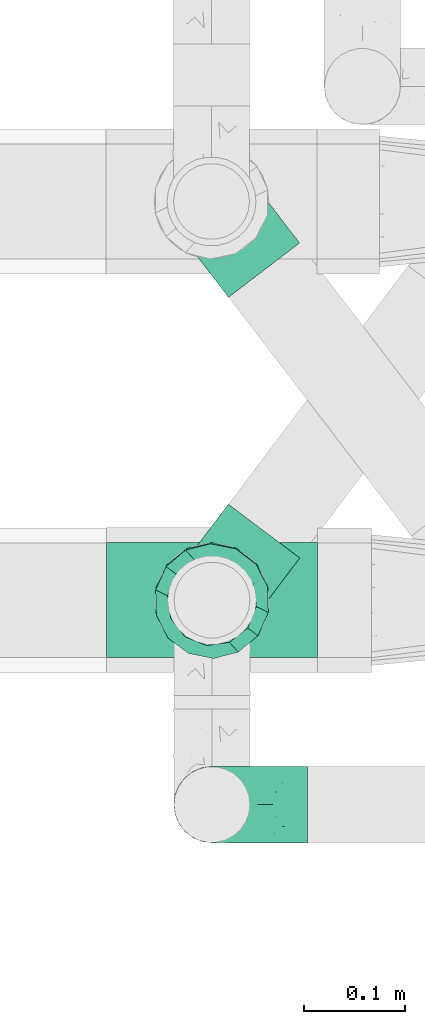
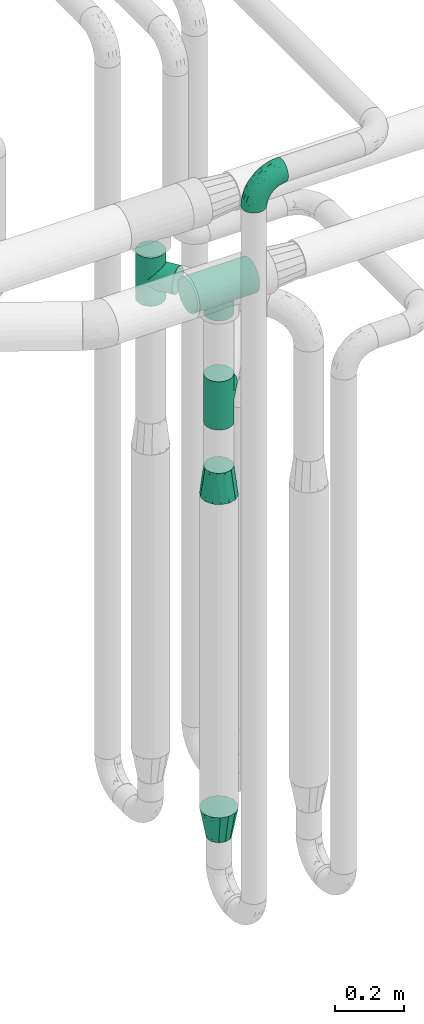
# One storey, part 629 of 827: 6 flow fittings.
"""IFC2X3 building model written with IfcOpenShell, lengths in millimetres."""

from ifc_helpers import new_model, entity, si_unit, converted_unit, derived_unit, direction, frame, origin, place, context, subcontext, project, spatial, faceted_brep, source, transform, mapped, material, type_object, type_shapes, element, save


model = new_model("IFC2X3")

# Units and contexts
model_context = context("Model", 3, precision=0.01, world=origin(), true_north=direction((6.12303176911189e-17, 1.0)))
body_context = subcontext(model_context, "Body", "Model", "MODEL_VIEW")
ifc_project = project(units=[si_unit("LENGTHUNIT", "METRE", prefix="MILLI"), si_unit("AREAUNIT", "SQUARE_METRE"), si_unit("VOLUMEUNIT", "CUBIC_METRE"), converted_unit("PLANEANGLEUNIT", "DEGREE", entity("IfcRatioMeasure", 0.0174532925199433), si_unit("PLANEANGLEUNIT", "RADIAN"), dimensions=[0, 0, 0, 0, 0, 0, 0]), si_unit("MASSUNIT", "GRAM", prefix="KILO"), derived_unit("MASSDENSITYUNIT", [(si_unit("MASSUNIT", "GRAM", prefix="KILO"), 1), (si_unit("LENGTHUNIT", "METRE"), -3)]), derived_unit("MOMENTOFINERTIAUNIT", [(si_unit("LENGTHUNIT", "METRE"), 4)]), si_unit("TIMEUNIT", "SECOND"), si_unit("FREQUENCYUNIT", "HERTZ"), si_unit("THERMODYNAMICTEMPERATUREUNIT", "DEGREE_CELSIUS"), derived_unit("THERMALTRANSMITTANCEUNIT", [(si_unit("MASSUNIT", "GRAM", prefix="KILO"), 1), (si_unit("THERMODYNAMICTEMPERATUREUNIT", "KELVIN"), -1), (si_unit("TIMEUNIT", "SECOND"), -3)]), derived_unit("VOLUMETRICFLOWRATEUNIT", [(si_unit("LENGTHUNIT", "METRE"), 3), (si_unit("TIMEUNIT", "SECOND"), -1)]), derived_unit("MASSFLOWRATEUNIT", [(si_unit("MASSUNIT", "GRAM", prefix="KILO"), 1), (si_unit("TIMEUNIT", "SECOND"), -1)]), derived_unit("ROTATIONALFREQUENCYUNIT", [(si_unit("TIMEUNIT", "SECOND"), -1)]), si_unit("ELECTRICCURRENTUNIT", "AMPERE"), si_unit("ELECTRICVOLTAGEUNIT", "VOLT"), si_unit("POWERUNIT", "WATT"), si_unit("FORCEUNIT", "NEWTON", prefix="KILO"), si_unit("ILLUMINANCEUNIT", "LUX"), si_unit("LUMINOUSFLUXUNIT", "LUMEN"), si_unit("LUMINOUSINTENSITYUNIT", "CANDELA"), derived_unit("USERDEFINED", [(si_unit("MASSUNIT", "GRAM", prefix="KILO"), -1), (si_unit("LENGTHUNIT", "METRE"), -2), (si_unit("TIMEUNIT", "SECOND"), 3), (si_unit("LUMINOUSFLUXUNIT", "LUMEN"), 1)]), derived_unit("LINEARVELOCITYUNIT", [(si_unit("LENGTHUNIT", "METRE"), 1), (si_unit("TIMEUNIT", "SECOND"), -1)]), si_unit("PRESSUREUNIT", "PASCAL"), derived_unit("USERDEFINED", [(si_unit("LENGTHUNIT", "METRE"), -2), (si_unit("MASSUNIT", "GRAM", prefix="KILO"), 1), (si_unit("TIMEUNIT", "SECOND"), -2)]), derived_unit("LINEARFORCEUNIT", [(si_unit("MASSUNIT", "GRAM", prefix="KILO"), 1), (si_unit("LENGTHUNIT", "METRE"), 1), (si_unit("TIMEUNIT", "SECOND"), -2), (si_unit("LENGTHUNIT", "METRE"), -1)]), derived_unit("PLANARFORCEUNIT", [(si_unit("MASSUNIT", "GRAM", prefix="KILO"), 1), (si_unit("LENGTHUNIT", "METRE"), 1), (si_unit("TIMEUNIT", "SECOND"), -2), (si_unit("LENGTHUNIT", "METRE"), -2)])], contexts=[model_context])

# Site, building, storey
site_placement = place(None, origin())
site = spatial("IfcSite", under=ifc_project, at=site_placement, CompositionType="ELEMENT")
building_placement = place(site_placement, origin())
building = spatial("IfcBuilding", under=site, at=building_placement, CompositionType="ELEMENT")
storey_placement = place(building_placement, frame((0.0, 0.0, 28200.0)))
storey = spatial("IfcBuildingStorey", under=building, at=storey_placement, Name="08", CompositionType="ELEMENT", Elevation=28200.0)

# Flow fittings
ifc_material = material()
pipe_fitting_type_1 = type_object("IfcPipeFittingType", Name="ADSK_1", PredefinedType="NOTDEFINED", material=ifc_material)
shared_shape_1 = source(origin(), body_context, "Body", "Brep", [
    faceted_brep([(-95.0, 19.02, -32.95), (-95.0, 9.85, -36.75), (-95.0, 0.0, -38.05), (-95.0, -9.85, -36.75), (-95.0, -19.03, -32.95), (-95.0, -26.91, -26.91), (-95.0, -32.95, -19.03), (-95.0, -36.75, -9.85), (-95.0, -38.05, 0.0), (-95.0, -36.75, 9.85), (-95.0, -32.95, 19.02), (-95.0, -26.91, 26.91), (-95.0, -19.03, 32.95), (-95.0, -9.85, 36.75), (-95.0, 0.0, 38.05), (-95.0, 9.85, 36.75), (-95.0, 19.02, 32.95), (-95.0, 26.91, 26.91), (-95.0, 32.95, 19.02), (-95.0, 36.75, 9.85), (-95.0, 38.05, 0.0), (-95.0, 36.75, -9.85), (-95.0, 32.95, -19.03), (-95.0, 26.91, -26.91), (0.0, 95.0, -38.05), (-9.85, 95.0, -36.75), (-19.02, 95.0, -32.95), (-26.91, 95.0, -26.91), (-32.95, 95.0, -19.03), (-36.75, 95.0, -9.85), (-38.05, 95.0, 0.0), (-36.75, 95.0, 9.85), (-32.95, 95.0, 19.02), (-26.91, 95.0, 26.91), (-19.02, 95.0, 32.95), (-9.85, 95.0, 36.75), (0.0, 95.0, 38.05), (9.85, 95.0, 36.75), (19.03, 95.0, 32.95), (26.91, 95.0, 26.91), (32.95, 95.0, 19.02), (36.75, 95.0, 9.85), (38.05, 95.0, 0.0), (36.75, 95.0, -9.85), (32.95, 95.0, -19.03), (26.91, 95.0, -26.91), (19.03, 95.0, -32.95), (9.85, 95.0, -36.75), (-7.99, -4.96, 6.3), (-0.92, 0.92, 0.0), (4.62, 8.1, 8.01), (-76.19, -35.57, 0.0), (-64.32, -32.32, 12.43), (20.51, 62.45, 28.68), (-60.56, -33.52, 0.0), (-70.4, -13.47, 34.42), (-39.61, -5.88, 32.32), (-49.6, 2.07, 37.1), (-70.34, -28.81, 21.71), (14.64, 40.81, 26.5), (5.88, 39.61, 32.32), (3.59, 20.77, 25.31), (-40.45, 68.06, 16.75), (-62.45, -20.51, 28.68), (-44.52, -26.87, 0.0), (-28.47, -20.22, 0.0), (-26.43, -17.83, 8.75), (-76.1, 39.63, 10.76), (-72.74, 37.58, 18.19), (-60.35, 46.18, 14.61), (-13.4, 13.4, 32.12), (-20.77, -3.59, 25.31), (-14.66, 81.47, 35.56), (-6.22, 71.26, 37.92), (-57.5, 42.48, 22.79), (-15.0, 34.74, 37.7), (-27.1, 12.08, 36.05), (-9.2, 28.81, 35.63), (-79.98, 23.7, 30.95), (-73.68, -4.3, 37.48), (-30.74, 21.67, 37.97), (-62.36, 47.59, 6.79), (-72.71, 32.83, 24.69), (-67.42, 7.02, 37.95), (-32.13, 75.27, 24.51), (-43.46, 51.47, 26.26), (-24.98, 73.15, 31.29), (20.59, 41.28, 19.85), (7.79, 16.09, 15.86), (-73.21, 42.39, 0.0), (-54.73, 54.73, 0.0), (-73.44, 15.79, 35.79), (-5.94, 4.32, 20.43), (28.81, 70.34, 21.71), (32.32, 64.32, 12.43), (-53.59, 26.2, 35.09), (-52.02, 19.31, 37.21), (21.38, 33.53, 10.34), (26.87, 44.52, 0.0), (-48.28, 12.14, 38.05), (4.3, 73.68, 37.48), (-44.08, -25.52, 12.79), (-41.28, -20.59, 19.85), (35.57, 76.19, 0.0), (-47.26, 54.3, 20.18), (-47.4, 61.99, 8.58), (-42.39, 73.21, 0.0), (-39.67, 78.86, 7.21), (-45.69, 36.84, 33.11), (-32.83, 50.13, 33.35), (13.47, 70.4, 34.42), (-18.25, 63.73, 36.07), (-40.63, -13.75, 27.22), (-16.63, 46.37, 37.95), (-53.47, 38.79, 28.59), (-26.07, 48.54, 36.15), (-34.51, 34.51, 36.86), (-2.07, 49.6, 37.1), (-22.79, -10.49, 19.23), (-61.73, 28.67, 31.87), (9.65, 14.7, 0.0), (20.22, 28.47, 0.0), (33.52, 60.56, 0.0), (-11.42, -5.44, 13.25), (-14.7, -9.65, 0.0), (-81.47, 14.66, -35.56), (-62.45, -20.51, -28.68), (-71.26, 6.22, -37.92), (-75.27, 32.13, -24.51), (-73.15, 24.98, -31.29), (13.47, 70.4, -34.42), (5.88, 39.61, -32.32), (-2.07, 49.6, -37.1), (-78.86, 39.67, -7.21), (-70.4, -13.47, -34.42), (-39.61, -5.88, -32.32), (-61.99, 47.4, -8.58), (32.32, 64.32, -12.43), (28.81, 70.34, -21.71), (-63.73, 18.25, -36.07), (-50.13, 32.83, -33.35), (4.3, 73.68, -37.48), (-7.02, 67.42, -37.95), (-39.63, 76.1, -10.76), (-46.18, 60.35, -14.61), (-47.59, 62.36, -6.79), (-64.32, -32.32, -12.43), (-26.2, 53.59, -35.09), (-15.79, 73.44, -35.79), (-19.31, 52.02, -37.21), (-37.58, 72.74, -18.19), (-70.34, -28.81, -21.71), (-42.48, 57.5, -22.79), (-38.79, 53.47, -28.59), (-51.47, 43.46, -26.26), (-32.83, 72.71, -24.69), (-46.37, 16.63, -37.95), (-73.68, -4.3, -37.48), (-41.28, -20.59, -19.85), (-44.08, -25.52, -12.79), (13.75, 40.63, -27.22), (20.51, 62.45, -28.68), (-68.06, 40.45, -16.75), (-54.3, 47.26, -20.18), (-12.14, 48.28, -38.05), (-21.67, 30.74, -37.97), (-36.84, 45.69, -33.11), (-11.42, -5.44, -13.25), (7.79, 16.09, -15.86), (4.62, 8.1, -8.01), (-23.7, 79.98, -30.95), (-26.43, -17.83, -8.75), (-7.99, -4.96, -6.3), (-40.81, -14.64, -26.5), (-20.77, -3.59, -25.31), (-34.74, 15.0, -37.7), (-12.08, 27.1, -36.05), (-28.81, 9.2, -35.63), (-22.79, -10.49, -19.23), (21.38, 33.53, -10.34), (20.59, 41.28, -19.85), (-48.54, 26.07, -36.15), (-49.6, 2.07, -37.1), (-13.4, 13.4, -32.12), (3.59, 20.77, -25.31), (-28.67, 61.73, -31.87), (-34.51, 34.51, -36.86), (-5.94, 4.32, -20.43)], [[[0, 1, 2, 3, 4, 5, 6, 7, 8, 9, 10, 11, 12, 13, 14, 15, 16, 17, 18, 19, 20, 21, 22, 23]], [[24, 25, 26, 27, 28, 29, 30, 31, 32, 33, 34, 35, 36, 37, 38, 39, 40, 41, 42, 43, 44, 45, 46, 47]], [[48, 49, 50]], [[51, 52, 9]], [[53, 39, 38]], [[9, 52, 10]], [[54, 52, 51]], [[55, 56, 57]], [[11, 10, 58]], [[59, 60, 61]], [[32, 31, 62]], [[63, 12, 11]], [[63, 55, 12]], [[64, 65, 66]], [[67, 68, 69]], [[70, 56, 71]], [[35, 72, 73]], [[69, 68, 74]], [[75, 76, 77]], [[16, 78, 17]], [[13, 79, 14]], [[76, 75, 80]], [[67, 69, 81]], [[18, 17, 82]], [[14, 79, 83]], [[20, 19, 67]], [[84, 85, 86]], [[87, 61, 88]], [[89, 81, 90]], [[18, 82, 68]], [[15, 91, 16]], [[14, 83, 15]], [[71, 92, 61]], [[17, 78, 82]], [[93, 87, 94]], [[95, 91, 96]], [[97, 98, 94]], [[86, 72, 34]], [[96, 99, 80]], [[37, 36, 100]], [[40, 39, 93]], [[40, 94, 41]], [[64, 66, 101]], [[93, 94, 40]], [[58, 102, 63]], [[94, 103, 41]], [[94, 87, 97]], [[104, 69, 74]], [[34, 33, 86]], [[105, 69, 104]], [[52, 58, 10]], [[106, 107, 30]], [[108, 109, 85]], [[105, 106, 90]], [[53, 110, 60]], [[86, 111, 72]], [[86, 109, 111]], [[33, 84, 86]], [[12, 55, 13]], [[112, 56, 63]], [[110, 38, 37]], [[34, 72, 35]], [[36, 35, 73]], [[111, 113, 73]], [[105, 107, 106]], [[110, 53, 38]], [[74, 114, 85]], [[91, 15, 83]], [[105, 90, 81]], [[107, 62, 31]], [[33, 32, 84]], [[115, 109, 116]], [[111, 115, 113]], [[100, 73, 117]], [[56, 55, 63]], [[79, 55, 57]], [[102, 118, 112]], [[56, 70, 76]], [[100, 110, 37]], [[117, 77, 60]], [[117, 60, 110]], [[60, 70, 61]], [[58, 52, 101]], [[63, 11, 58]], [[39, 53, 93]], [[87, 93, 53]], [[96, 91, 83]], [[78, 91, 119]], [[32, 62, 84]], [[84, 62, 104]], [[86, 85, 109]], [[85, 114, 108]], [[80, 113, 116]], [[117, 73, 113]], [[80, 116, 96]], [[80, 57, 76]], [[71, 112, 118]], [[61, 87, 59]], [[62, 107, 105]], [[97, 120, 121]], [[70, 71, 61]], [[71, 118, 92]], [[73, 100, 36]], [[110, 100, 117]], [[55, 79, 13]], [[83, 79, 57]], [[96, 83, 99]], [[116, 108, 95]], [[50, 97, 88]], [[97, 87, 88]], [[50, 49, 120]], [[122, 94, 98]], [[89, 20, 67]], [[105, 81, 69]], [[89, 67, 81]], [[68, 19, 18]], [[68, 67, 19]], [[74, 68, 82]], [[114, 82, 119]], [[74, 85, 104]], [[82, 114, 74]], [[114, 119, 108]], [[95, 108, 119]], [[116, 109, 108]], [[123, 48, 50]], [[97, 50, 120]], [[123, 50, 88]], [[91, 95, 119]], [[116, 95, 96]], [[84, 104, 85]], [[104, 62, 105]], [[83, 57, 99]], [[57, 80, 99]], [[66, 48, 123]], [[66, 124, 48]], [[118, 66, 123]], [[124, 66, 65]], [[66, 118, 101]], [[54, 64, 52]], [[124, 49, 48]], [[30, 107, 31]], [[91, 78, 16]], [[82, 78, 119]], [[56, 76, 57]], [[77, 76, 70]], [[60, 77, 70]], [[77, 117, 75]], [[117, 113, 75]], [[113, 80, 75]], [[9, 8, 51]], [[103, 94, 122]], [[103, 42, 41]], [[73, 72, 111]], [[113, 115, 116]], [[111, 109, 115]], [[102, 112, 63]], [[71, 56, 112]], [[118, 102, 101]], [[92, 123, 88]], [[123, 92, 118]], [[61, 92, 88]], [[87, 53, 59]], [[60, 59, 53]], [[97, 121, 98]], [[58, 101, 102]], [[64, 101, 52]], [[125, 1, 0]], [[126, 5, 4]], [[2, 1, 127]], [[1, 125, 127]], [[128, 129, 23]], [[130, 131, 132]], [[89, 133, 20]], [[126, 134, 135]], [[136, 89, 90]], [[137, 138, 44]], [[139, 129, 140]], [[24, 141, 142]], [[143, 144, 145]], [[125, 129, 139]], [[6, 146, 7]], [[147, 148, 149]], [[146, 51, 7]], [[143, 150, 144]], [[146, 6, 151]], [[152, 153, 154]], [[126, 4, 134]], [[0, 23, 129]], [[28, 155, 150]], [[43, 42, 103]], [[54, 146, 64]], [[139, 156, 127]], [[157, 3, 2]], [[151, 158, 159]], [[160, 131, 161]], [[22, 21, 162]], [[136, 144, 163]], [[149, 164, 165]], [[24, 142, 25]], [[166, 140, 154]], [[154, 129, 128]], [[143, 30, 29]], [[167, 168, 169]], [[155, 28, 27]], [[26, 170, 27]], [[171, 167, 172]], [[26, 25, 148]], [[27, 170, 155]], [[173, 135, 174]], [[144, 150, 152]], [[175, 176, 177]], [[24, 47, 141]], [[45, 161, 46]], [[148, 25, 142]], [[176, 175, 165]], [[64, 159, 171]], [[138, 45, 44]], [[130, 46, 161]], [[137, 44, 43]], [[178, 159, 158]], [[137, 103, 122]], [[163, 144, 152]], [[136, 133, 89]], [[103, 137, 43]], [[6, 5, 151]], [[178, 158, 173]], [[134, 4, 3]], [[178, 173, 174]], [[137, 98, 179]], [[145, 90, 106]], [[138, 180, 161]], [[46, 130, 47]], [[136, 90, 145]], [[133, 162, 21]], [[23, 22, 128]], [[139, 140, 181]], [[139, 181, 156]], [[157, 127, 182]], [[157, 134, 3]], [[182, 177, 135]], [[182, 135, 134]], [[135, 183, 174]], [[131, 130, 161]], [[141, 130, 132]], [[160, 180, 184]], [[131, 183, 176]], [[5, 126, 151]], [[158, 151, 126]], [[180, 138, 137]], [[161, 45, 138]], [[149, 148, 142]], [[170, 148, 185]], [[22, 162, 128]], [[128, 162, 163]], [[129, 154, 140]], [[154, 153, 166]], [[165, 156, 186]], [[182, 127, 156]], [[165, 186, 149]], [[165, 132, 176]], [[131, 184, 183]], [[187, 167, 178]], [[184, 168, 187]], [[167, 169, 172]], [[184, 180, 168]], [[174, 183, 184]], [[127, 157, 2]], [[134, 157, 182]], [[130, 141, 47]], [[142, 141, 132]], [[149, 142, 164]], [[186, 166, 147]], [[180, 179, 168]], [[169, 179, 120]], [[137, 179, 180]], [[179, 121, 120]], [[106, 30, 143]], [[136, 145, 144]], [[106, 143, 145]], [[150, 29, 28]], [[150, 143, 29]], [[152, 150, 155]], [[153, 155, 185]], [[152, 154, 163]], [[155, 153, 152]], [[153, 185, 166]], [[147, 166, 185]], [[186, 140, 166]], [[169, 120, 49]], [[169, 49, 172]], [[179, 169, 168]], [[148, 147, 185]], [[186, 147, 149]], [[128, 163, 154]], [[163, 162, 136]], [[142, 132, 164]], [[132, 165, 164]], [[171, 124, 65]], [[124, 171, 172]], [[64, 146, 159]], [[171, 159, 178]], [[171, 65, 64]], [[172, 49, 124]], [[162, 133, 136]], [[20, 133, 21]], [[148, 170, 26]], [[155, 170, 185]], [[131, 176, 132]], [[177, 176, 183]], [[135, 177, 183]], [[177, 182, 175]], [[182, 156, 175]], [[156, 165, 175]], [[51, 146, 54]], [[51, 8, 7]], [[129, 125, 0]], [[127, 125, 139]], [[140, 186, 181]], [[156, 181, 186]], [[158, 126, 173]], [[135, 173, 126]], [[187, 178, 174]], [[171, 178, 167]], [[184, 187, 174]], [[167, 187, 168]], [[180, 160, 161]], [[184, 131, 160]], [[98, 137, 122]], [[98, 121, 179]], [[151, 159, 146]]]),
])
type_shapes(pipe_fitting_type_1, [shared_shape_1])
flow_fitting_1_placement = place(storey_placement, frame((43595.53, 13686.84, 3000.0), z_axis=(0.0, 1.0, 0.0), x_axis=(0.0, 0.0, 1.0)))
element("IfcFlowFitting", 1, at=flow_fitting_1_placement, inside=storey, type_object=pipe_fitting_type_1, material=ifc_material, Name="ADSK_1", ObjectType="ADSK_1", context=body_context, shape_type="MappedRepresentation", body=[
    mapped(shared_shape_1, transform((0.0, 0.0, 0.0), scale=1.0)),
])
pipe_fitting_type_2 = type_object("IfcPipeFittingType", Name="ADSK_1", PredefinedType="NOTDEFINED", material=ifc_material)
shared_shape_2 = source(origin(), body_context, "Body", "Brep", [
    faceted_brep([(-86.0, 22.22, -38.49), (-86.0, 11.5, -42.94), (-86.0, 0.0, -44.45), (-86.0, -11.5, -42.94), (-86.0, -22.23, -38.49), (-86.0, -26.83, -34.96), (-86.0, -31.43, -31.43), (-86.0, -34.96, -26.83), (-86.0, -38.49, -22.23), (-86.0, -40.72, -16.86), (-86.0, -42.94, -11.5), (-86.0, -44.45, 0.0), (-86.0, -42.94, 11.5), (-86.0, -40.72, 16.86), (-86.0, -38.49, 22.22), (-86.0, -34.96, 26.83), (-86.0, -31.43, 31.43), (-86.0, -26.83, 34.96), (-86.0, -22.23, 38.49), (-86.0, -11.5, 42.94), (-86.0, 0.0, 44.45), (-86.0, 11.5, 42.94), (-86.0, 22.22, 38.49), (-86.0, 31.43, 31.43), (-86.0, 38.49, 22.22), (-86.0, 42.94, 11.5), (-86.0, 44.45, 0.0), (-86.0, 42.94, -11.5), (-86.0, 38.49, -22.23), (-86.0, 31.43, -31.43), (86.0, 0.0, -44.45), (86.0, 11.5, -42.94), (86.0, 22.22, -38.49), (86.0, 31.43, -31.43), (86.0, 38.49, -22.23), (86.0, 42.94, -11.5), (86.0, 44.45, 0.0), (86.0, 42.94, 11.5), (86.0, 38.49, 22.22), (86.0, 31.43, 31.43), (86.0, 22.22, 38.49), (86.0, 11.5, 42.94), (86.0, 0.0, 44.45), (86.0, -11.5, 42.94), (86.0, -22.23, 38.49), (86.0, -26.83, 34.96), (86.0, -31.43, 31.43), (86.0, -34.96, 26.83), (86.0, -38.49, 22.22), (86.0, -40.72, 16.86), (86.0, -42.94, 11.5), (86.0, -44.45, 0.0), (86.0, -42.94, -11.5), (86.0, -40.72, -16.86), (86.0, -38.49, -22.23), (86.0, -34.96, -26.83), (86.0, -31.43, -31.43), (86.0, -26.83, -34.96), (86.0, -22.23, -38.49), (86.0, -11.5, -42.94), (43.21, -43.21, 10.43), (44.45, -44.45, 0.0), (-43.21, -43.21, 10.43), (-44.45, -44.45, 0.0), (41.49, -41.49, 15.14), (39.77, -39.77, 19.85), (21.97, -21.97, 38.64), (34.75, -34.75, 27.71), (28.69, -28.69, 33.95), (-41.49, -41.49, 15.14), (-39.77, -39.77, 19.85), (-21.97, -21.97, 38.64), (-34.75, -34.75, 27.71), (-28.69, -28.69, 33.95), (-14.84, -14.84, 41.9), (7.47, -7.47, 43.82), (14.84, -14.84, 41.9), (0.0, 0.0, 44.45), (-7.47, -7.47, 43.82), (7.47, -7.47, -43.82), (0.0, 0.0, -44.45), (14.84, -14.84, -41.9), (-28.69, -28.69, -33.95), (-7.47, -7.47, -43.82), (-41.49, -41.49, -15.14), (-43.21, -43.21, -10.43), (-34.75, -34.75, -27.71), (-14.84, -14.84, -41.9), (21.97, -21.97, -38.64), (28.69, -28.69, -33.95), (-39.77, -39.77, -19.85), (34.75, -34.75, -27.71), (43.21, -43.21, -10.43), (41.49, -41.49, -15.14), (39.77, -39.77, -19.85), (-21.97, -21.97, -38.64), (31.43, -86.0, -31.43), (38.49, -86.0, -22.23), (42.94, -86.0, -11.5), (44.45, -86.0, 0.0), (42.94, -86.0, 11.5), (38.49, -86.0, 22.22), (31.43, -86.0, 31.43), (22.23, -86.0, 38.49), (11.5, -86.0, 42.94), (0.0, -86.0, 44.45), (-11.5, -86.0, 42.94), (-22.22, -86.0, 38.49), (-31.43, -86.0, 31.43), (-38.49, -86.0, 22.22), (-42.94, -86.0, 11.5), (-44.45, -86.0, 0.0), (-42.94, -86.0, -11.5), (-38.49, -86.0, -22.23), (-31.43, -86.0, -31.43), (-22.22, -86.0, -38.49), (-11.5, -86.0, -42.94), (0.0, -86.0, -44.45), (11.5, -86.0, -42.94), (22.23, -86.0, -38.49)], [[[0, 1, 2, 3, 4, 5, 6, 7, 8, 9, 10, 11, 12, 13, 14, 15, 16, 17, 18, 19, 20, 21, 22, 23, 24, 25, 26, 27, 28, 29]], [[30, 31, 32, 33, 34, 35, 36, 37, 38, 39, 40, 41, 42, 43, 44, 45, 46, 47, 48, 49, 50, 51, 52, 53, 54, 55, 56, 57, 58, 59]], [[51, 50, 60]], [[60, 61, 51]], [[62, 11, 63]], [[50, 49, 64]], [[49, 48, 65]], [[44, 66, 45]], [[46, 67, 48, 47]], [[67, 46, 68]], [[48, 67, 65]], [[68, 46, 45]], [[12, 69, 13]], [[70, 13, 69]], [[11, 62, 12]], [[12, 62, 69]], [[71, 18, 17]], [[72, 73, 16]], [[72, 16, 15, 14]], [[16, 73, 17]], [[71, 74, 18]], [[72, 14, 70]], [[49, 65, 64]], [[45, 66, 68]], [[43, 42, 75]], [[50, 64, 60]], [[66, 44, 76]], [[75, 76, 43]], [[75, 42, 77]], [[78, 77, 20]], [[76, 44, 43]], [[24, 23, 39, 38]], [[25, 24, 38, 37]], [[22, 21, 41, 40]], [[23, 22, 40, 39]], [[41, 21, 20, 77, 42]], [[26, 25, 37, 36]], [[70, 14, 13]], [[78, 19, 74]], [[19, 78, 20]], [[19, 18, 74]], [[71, 17, 73]], [[29, 28, 34, 33]], [[27, 35, 34, 28]], [[26, 36, 35, 27]], [[0, 29, 33, 32]], [[30, 59, 79]], [[31, 30, 80, 2, 1]], [[79, 59, 81]], [[82, 6, 5]], [[32, 31, 1, 0]], [[59, 58, 81]], [[30, 79, 80]], [[80, 83, 2]], [[10, 84, 85]], [[86, 8, 7, 6]], [[83, 87, 3]], [[2, 83, 3]], [[87, 4, 3]], [[88, 57, 89]], [[57, 56, 89]], [[9, 90, 84]], [[88, 58, 57]], [[91, 89, 56]], [[55, 54, 91, 56]], [[58, 88, 81]], [[52, 92, 93]], [[92, 52, 51]], [[94, 53, 93]], [[61, 92, 51]], [[85, 63, 11]], [[54, 94, 91]], [[82, 5, 95]], [[52, 93, 53]], [[5, 4, 95]], [[6, 82, 86]], [[94, 54, 53]], [[95, 4, 87]], [[10, 9, 84]], [[90, 9, 8]], [[10, 85, 11]], [[90, 8, 86]], [[96, 97, 98, 99, 100, 101, 102, 103, 104, 105, 106, 107, 108, 109, 110, 111, 112, 113, 114, 115, 116, 117, 118, 119]], [[62, 63, 111]], [[110, 62, 111]], [[108, 107, 73]], [[72, 109, 108]], [[70, 110, 109]], [[74, 107, 106]], [[110, 70, 69, 62]], [[73, 72, 108]], [[70, 109, 72]], [[74, 71, 107]], [[105, 77, 78]], [[74, 106, 78]], [[73, 107, 71]], [[78, 106, 105]], [[75, 105, 104]], [[103, 76, 104]], [[101, 100, 65]], [[67, 102, 101]], [[68, 103, 102]], [[60, 100, 99]], [[68, 66, 103]], [[76, 75, 104]], [[66, 76, 103]], [[61, 60, 99]], [[65, 67, 101]], [[100, 60, 64, 65]], [[68, 102, 67]], [[105, 75, 77]], [[61, 99, 92]], [[98, 92, 99]], [[96, 119, 89]], [[94, 98, 97]], [[96, 91, 97]], [[81, 119, 118]], [[98, 94, 93, 92]], [[89, 91, 96]], [[94, 97, 91]], [[81, 88, 119]], [[117, 80, 79]], [[81, 118, 79]], [[89, 119, 88]], [[79, 118, 117]], [[83, 117, 116]], [[115, 87, 116]], [[113, 112, 90]], [[86, 114, 113]], [[82, 115, 114]], [[85, 112, 111]], [[82, 95, 115]], [[87, 83, 116]], [[95, 87, 115]], [[63, 85, 111]], [[90, 86, 113]], [[112, 85, 84, 90]], [[82, 114, 86]], [[117, 83, 80]]]),
])
type_shapes(pipe_fitting_type_2, [shared_shape_2])
for number, where, z_axis, x_axis, name in (
    (2, (43595.53, 13890.17, 2100.0), (0.798635510047291, -0.601815023152051, 0.0), (0.0, 0.0, 1.0), "ADSK_1"),
    (3, (43595.03, 14286.62, 2300.0), (-0.794341681216582, -0.607471228521989, 0.0), (0.0, 0.0, 1.0), "ADSK_1"),
):
    element("IfcFlowFitting", number, at=place(storey_placement, frame(where, z_axis=z_axis, x_axis=x_axis)), inside=storey, type_object=pipe_fitting_type_2, material=ifc_material, Name=name, ObjectType="ADSK_1", context=body_context, shape_type="MappedRepresentation", body=[
        mapped(shared_shape_2, transform((0.0, 0.0, 0.0), scale=1.0)),
    ])
pipe_fitting_type_3 = type_object("IfcPipeFittingType", Name="ADSK_1", PredefinedType="NOTDEFINED", material=ifc_material)
shared_shape_3 = source(origin(), body_context, "Body", "Brep", [
    faceted_brep([(102.0, -57.15, 0.0), (102.0, -54.32, -12.4), (102.0, -51.49, -24.8), (102.0, -43.56, -34.74), (102.0, -35.63, -44.68), (102.0, -24.17, -50.2), (102.0, -12.72, -55.72), (102.0, 0.0, -55.72), (102.0, 12.72, -55.72), (102.0, 24.17, -50.2), (102.0, 35.63, -44.68), (102.0, 43.56, -34.74), (102.0, 51.49, -24.8), (102.0, 54.32, -12.4), (102.0, 57.15, 0.0), (102.0, 54.32, 12.4), (102.0, 51.49, 24.8), (102.0, 43.56, 34.74), (102.0, 35.63, 44.68), (102.0, 24.17, 50.2), (102.0, 12.72, 55.72), (102.0, 0.0, 55.72), (102.0, -12.72, 55.72), (102.0, -24.17, 50.2), (102.0, -35.63, 44.68), (102.0, -43.56, 34.74), (102.0, -51.49, 24.8), (102.0, -54.32, 12.4), (0.0, -38.49, -22.22), (0.0, -41.47, -11.11), (0.0, -44.45, 0.0), (0.0, -41.47, 11.11), (0.0, -38.49, 22.23), (0.0, -30.36, 30.36), (0.0, -22.23, 38.49), (0.0, -11.11, 41.47), (0.0, 0.0, 44.45), (0.0, 11.11, 41.47), (0.0, 22.23, 38.49), (0.0, 30.36, 30.36), (0.0, 38.49, 22.23), (0.0, 41.47, 11.11), (0.0, 44.45, 0.0), (0.0, 41.47, -11.11), (0.0, 38.49, -22.23), (0.0, 30.36, -30.36), (0.0, 22.22, -38.49), (0.0, 11.11, -41.47), (0.0, 0.0, -44.45), (0.0, -11.11, -41.47), (0.0, -22.23, -38.49), (0.0, -30.36, -30.36)], [[[0, 1, 2, 3, 4, 5, 6, 7, 8, 9, 10, 11, 12, 13, 14, 15, 16, 17, 18, 19, 20, 21, 22, 23, 24, 25, 26, 27]], [[28, 29, 30, 31, 32, 33, 34, 35, 36, 37, 38, 39, 40, 41, 42, 43, 44, 45, 46, 47, 48, 49, 50, 51]], [[28, 2, 29]], [[11, 10, 45]], [[11, 44, 12]], [[3, 2, 28]], [[30, 29, 1]], [[42, 13, 43]], [[30, 1, 0]], [[46, 10, 9]], [[48, 8, 7, 6]], [[28, 51, 3]], [[29, 2, 1]], [[47, 46, 9]], [[5, 4, 50]], [[51, 4, 3]], [[8, 48, 47]], [[13, 42, 14]], [[51, 50, 4]], [[8, 47, 9]], [[5, 49, 6]], [[44, 11, 45]], [[43, 12, 44]], [[10, 46, 45]], [[49, 5, 50]], [[49, 48, 6]], [[13, 12, 43]], [[40, 16, 41]], [[25, 24, 33]], [[25, 32, 26]], [[17, 16, 40]], [[42, 41, 15]], [[30, 27, 31]], [[42, 15, 14]], [[34, 24, 23]], [[36, 22, 21, 20]], [[40, 39, 17]], [[41, 16, 15]], [[35, 34, 23]], [[19, 18, 38]], [[39, 18, 17]], [[22, 36, 35]], [[27, 30, 0]], [[39, 38, 18]], [[22, 35, 23]], [[19, 37, 20]], [[32, 25, 33]], [[31, 26, 32]], [[24, 34, 33]], [[37, 19, 38]], [[37, 36, 20]], [[27, 26, 31]]]),
])
type_shapes(pipe_fitting_type_3, [shared_shape_3])
flow_fitting_2_placement = place(storey_placement, frame((43595.53, 13889.16, 1860.0), z_axis=(0.601815023152051, 0.798635510047291, 0.0), x_axis=(0.0, 0.0, -1.0)))
element("IfcFlowFitting", 4, at=flow_fitting_2_placement, inside=storey, type_object=pipe_fitting_type_3, material=ifc_material, Name="ADSK_1", ObjectType="ADSK_1", context=body_context, shape_type="MappedRepresentation", body=[
    mapped(shared_shape_3, transform((0.0, 0.0, 0.0), scale=1.0)),
])
pipe_fitting_type_4 = type_object("IfcPipeFittingType", Name="ADSK_1", PredefinedType="NOTDEFINED", material=ifc_material)
shared_shape_4 = source(origin(), body_context, "Body", "Brep", [
    faceted_brep([(102.0, 38.05, 0.0), (102.0, 35.5, 9.51), (102.0, 32.95, 19.03), (102.0, 25.99, 25.99), (102.0, 19.02, 32.95), (102.0, 9.51, 35.5), (102.0, 0.0, 38.05), (102.0, -9.51, 35.5), (102.0, -19.03, 32.95), (102.0, -25.99, 25.99), (102.0, -32.95, 19.03), (102.0, -35.5, 9.51), (102.0, -38.05, 0.0), (102.0, -35.5, -9.51), (102.0, -32.95, -19.02), (102.0, -25.99, -25.99), (102.0, -19.03, -32.95), (102.0, -9.51, -35.5), (102.0, 0.0, -38.05), (102.0, 9.51, -35.5), (102.0, 19.02, -32.95), (102.0, 25.99, -25.99), (102.0, 32.95, -19.02), (102.0, 35.5, -9.51), (0.0, 43.56, 34.74), (0.0, 51.49, 24.8), (0.0, 54.32, 12.4), (0.0, 57.15, 0.0), (0.0, 54.32, -12.4), (0.0, 51.49, -24.8), (0.0, 43.56, -34.74), (0.0, 35.63, -44.68), (0.0, 24.17, -50.2), (0.0, 12.72, -55.72), (0.0, 0.0, -55.72), (0.0, -12.72, -55.72), (0.0, -24.17, -50.2), (0.0, -35.63, -44.68), (0.0, -43.56, -34.74), (0.0, -51.49, -24.8), (0.0, -54.32, -12.4), (0.0, -57.15, 0.0), (0.0, -54.32, 12.4), (0.0, -51.49, 24.8), (0.0, -43.56, 34.74), (0.0, -35.63, 44.68), (0.0, -24.17, 50.2), (0.0, -12.72, 55.72), (0.0, 0.0, 55.72), (0.0, 12.72, 55.72), (0.0, 24.17, 50.2), (0.0, 35.63, 44.68)], [[[0, 1, 2, 3, 4, 5, 6, 7, 8, 9, 10, 11, 12, 13, 14, 15, 16, 17, 18, 19, 20, 21, 22, 23]], [[24, 25, 26, 27, 28, 29, 30, 31, 32, 33, 34, 35, 36, 37, 38, 39, 40, 41, 42, 43, 44, 45, 46, 47, 48, 49, 50, 51]], [[32, 31, 20]], [[40, 12, 41]], [[30, 29, 22]], [[22, 29, 23]], [[40, 39, 13]], [[12, 40, 13]], [[37, 16, 15]], [[18, 35, 34, 33]], [[16, 37, 36]], [[32, 19, 33]], [[36, 17, 16]], [[22, 21, 30]], [[38, 14, 39]], [[23, 29, 28]], [[21, 31, 30]], [[0, 28, 27]], [[36, 35, 17]], [[0, 23, 28]], [[39, 14, 13]], [[14, 38, 15]], [[21, 20, 31]], [[19, 18, 33]], [[35, 18, 17]], [[38, 37, 15]], [[19, 32, 20]], [[46, 45, 8]], [[26, 0, 27]], [[44, 43, 10]], [[10, 43, 11]], [[26, 25, 1]], [[0, 26, 1]], [[51, 4, 3]], [[6, 49, 48, 47]], [[4, 51, 50]], [[46, 7, 47]], [[50, 5, 4]], [[10, 9, 44]], [[24, 2, 25]], [[11, 43, 42]], [[9, 45, 44]], [[12, 42, 41]], [[50, 49, 5]], [[12, 11, 42]], [[25, 2, 1]], [[2, 24, 3]], [[9, 8, 45]], [[7, 6, 47]], [[49, 6, 5]], [[24, 51, 3]], [[7, 46, 8]]]),
])
type_shapes(pipe_fitting_type_4, [shared_shape_4])
flow_fitting_3_placement = place(storey_placement, frame((43595.53, 13890.17, 643.02), z_axis=(1.0, 0.0, 0.0), x_axis=(0.0, 0.0, -1.0)))
element("IfcFlowFitting", 5, at=flow_fitting_3_placement, inside=storey, type_object=pipe_fitting_type_4, material=ifc_material, Name="ADSK_1", ObjectType="ADSK_1", context=body_context, shape_type="MappedRepresentation", body=[
    mapped(shared_shape_4, transform((0.0, 0.0, 0.0), scale=1.0)),
])
pipe_fitting_type_5 = type_object("IfcPipeFittingType", Name="ADSK_1", PredefinedType="NOTDEFINED", material=ifc_material)
shared_shape_5 = source(origin(), body_context, "Body", "Brep", [
    faceted_brep([(-105.0, 28.57, -49.49), (-105.0, 14.79, -55.2), (-105.0, 0.0, -57.15), (-105.0, -14.79, -55.2), (-105.0, -28.58, -49.49), (-105.0, -40.41, -40.41), (-105.0, -49.49, -28.58), (-105.0, -55.2, -14.79), (-105.0, -57.15, 0.0), (-105.0, -55.2, 14.79), (-105.0, -49.49, 28.57), (-105.0, -40.41, 40.41), (-105.0, -28.58, 49.49), (-105.0, -14.79, 55.2), (-105.0, 0.0, 57.15), (-105.0, 14.79, 55.2), (-105.0, 28.57, 49.49), (-105.0, 40.41, 40.41), (-105.0, 49.49, 28.57), (-105.0, 55.2, 14.79), (-105.0, 57.15, 0.0), (-105.0, 55.2, -14.79), (-105.0, 49.49, -28.58), (-105.0, 40.41, -40.41), (105.0, 0.0, -57.15), (105.0, 14.79, -55.2), (105.0, 28.57, -49.49), (105.0, 40.41, -40.41), (105.0, 49.49, -28.58), (105.0, 55.2, -14.79), (105.0, 57.15, 0.0), (105.0, 55.2, 14.79), (105.0, 49.49, 28.57), (105.0, 40.41, 40.41), (105.0, 28.57, 49.49), (105.0, 14.79, 55.2), (105.0, 0.0, 57.15), (105.0, -14.79, 55.2), (105.0, -28.58, 49.49), (105.0, -40.41, 40.41), (105.0, -49.49, 28.57), (105.0, -55.2, 14.79), (105.0, -57.15, 0.0), (105.0, -55.2, -14.79), (105.0, -49.49, -28.58), (105.0, -40.41, -40.41), (105.0, -28.58, -49.49), (105.0, -14.79, -55.2), (44.45, -57.15, 0.0), (-44.45, -57.15, 0.0), (41.54, -54.92, 15.82), (42.99, -56.03, 7.91), (22.42, -42.34, 38.38), (33.74, -49.28, 28.94), (8.06, -36.82, 43.71), (-43.0, -56.04, 7.9), (-41.54, -54.92, 15.81), (-22.42, -42.34, 38.38), (-8.09, -36.82, 43.71), (-33.74, -49.28, 28.94), (-0.01, -36.82, 43.71), (8.06, -36.82, -43.71), (22.42, -42.34, -38.38), (33.74, -49.28, -28.94), (41.54, -54.92, -15.82), (42.99, -56.03, -7.91), (-8.09, -36.82, -43.71), (-22.42, -42.34, -38.38), (-33.74, -49.28, -28.94), (-41.54, -54.92, -15.81), (-43.0, -56.04, -7.9), (-0.01, -36.82, -43.71), (38.49, -98.0, -22.23), (42.94, -98.0, -11.5), (44.45, -98.0, 0.0), (42.94, -98.0, 11.5), (38.49, -98.0, 22.22), (31.43, -98.0, 31.43), (22.23, -98.0, 38.49), (11.5, -98.0, 42.94), (0.0, -98.0, 44.45), (-11.5, -98.0, 42.94), (-22.22, -98.0, 38.49), (-31.43, -98.0, 31.43), (-38.49, -98.0, 22.22), (-42.94, -98.0, 11.5), (-44.45, -98.0, 0.0), (-42.94, -98.0, -11.5), (-38.49, -98.0, -22.23), (-31.43, -98.0, -31.43), (-22.22, -98.0, -38.49), (-11.5, -98.0, -42.94), (0.0, -98.0, -44.45), (11.5, -98.0, -42.94), (22.23, -98.0, -38.49), (31.43, -98.0, -31.43)], [[[0, 1, 2, 3, 4, 5, 6, 7, 8, 9, 10, 11, 12, 13, 14, 15, 16, 17, 18, 19, 20, 21, 22, 23]], [[24, 25, 26, 27, 28, 29, 30, 31, 32, 33, 34, 35, 36, 37, 38, 39, 40, 41, 42, 43, 44, 45, 46, 47]], [[42, 41, 48]], [[9, 8, 49]], [[41, 50, 51, 48]], [[41, 40, 50]], [[40, 39, 52]], [[52, 53, 40]], [[54, 52, 39]], [[39, 38, 54]], [[40, 53, 50]], [[9, 49, 55, 56]], [[56, 10, 9]], [[57, 58, 11]], [[59, 57, 10]], [[59, 10, 56]], [[10, 57, 11]], [[58, 12, 11]], [[12, 58, 60, 54]], [[14, 13, 37, 36]], [[13, 12, 38, 37]], [[15, 14, 36, 35]], [[32, 31, 19, 18]], [[17, 16, 34, 33]], [[18, 17, 33, 32]], [[35, 34, 16, 15]], [[20, 19, 31, 30]], [[38, 12, 54]], [[21, 29, 28, 22]], [[28, 27, 23, 22]], [[30, 29, 21, 20]], [[24, 47, 3, 2]], [[1, 0, 26, 25]], [[2, 1, 25, 24]], [[27, 26, 0, 23]], [[46, 4, 3, 47]], [[46, 61, 4]], [[62, 44, 63]], [[44, 62, 45]], [[62, 61, 45]], [[45, 61, 46]], [[43, 42, 48]], [[7, 49, 8]], [[43, 64, 44]], [[43, 48, 65, 64]], [[44, 64, 63]], [[66, 67, 5]], [[6, 67, 68]], [[67, 6, 5]], [[66, 5, 4]], [[7, 69, 70, 49]], [[69, 7, 6]], [[69, 6, 68]], [[4, 61, 71, 66]], [[72, 73, 74, 75, 76, 77, 78, 79, 80, 81, 82, 83, 84, 85, 86, 87, 88, 89, 90, 91, 92, 93, 94, 95]], [[56, 85, 84]], [[57, 83, 82]], [[84, 83, 59]], [[57, 82, 81]], [[55, 86, 85]], [[49, 86, 55]], [[85, 56, 55]], [[59, 56, 84]], [[83, 57, 59]], [[51, 74, 48]], [[81, 58, 57]], [[80, 54, 60, 58]], [[52, 79, 78]], [[77, 52, 78]], [[50, 76, 75]], [[77, 76, 53]], [[54, 80, 79]], [[79, 52, 54]], [[80, 58, 81]], [[52, 77, 53]], [[53, 76, 50]], [[51, 50, 75]], [[74, 51, 75]], [[73, 65, 74]], [[70, 69, 87]], [[92, 61, 93]], [[70, 86, 49]], [[73, 64, 65]], [[73, 72, 64]], [[95, 63, 72]], [[65, 48, 74]], [[64, 72, 63]], [[94, 93, 62]], [[62, 63, 95]], [[62, 93, 61]], [[62, 95, 94]], [[92, 66, 71, 61]], [[67, 91, 90]], [[89, 67, 90]], [[69, 88, 87]], [[89, 88, 68]], [[66, 92, 91]], [[91, 67, 66]], [[67, 89, 68]], [[68, 88, 69]], [[86, 70, 87]]]),
])
type_shapes(pipe_fitting_type_5, [shared_shape_5])
flow_fitting_4_placement = place(storey_placement, frame((43595.53, 13890.17, 2500.0), z_axis=(0.0, -1.0, 0.0), x_axis=(1.0, 0.0, 0.0)))
element("IfcFlowFitting", 6, at=flow_fitting_4_placement, inside=storey, type_object=pipe_fitting_type_5, material=ifc_material, Name="ADSK_1", ObjectType="ADSK_1", context=body_context, shape_type="MappedRepresentation", body=[
    mapped(shared_shape_5, transform((0.0, 0.0, 0.0), scale=1.0)),
])

save(model, "model.ifc")
